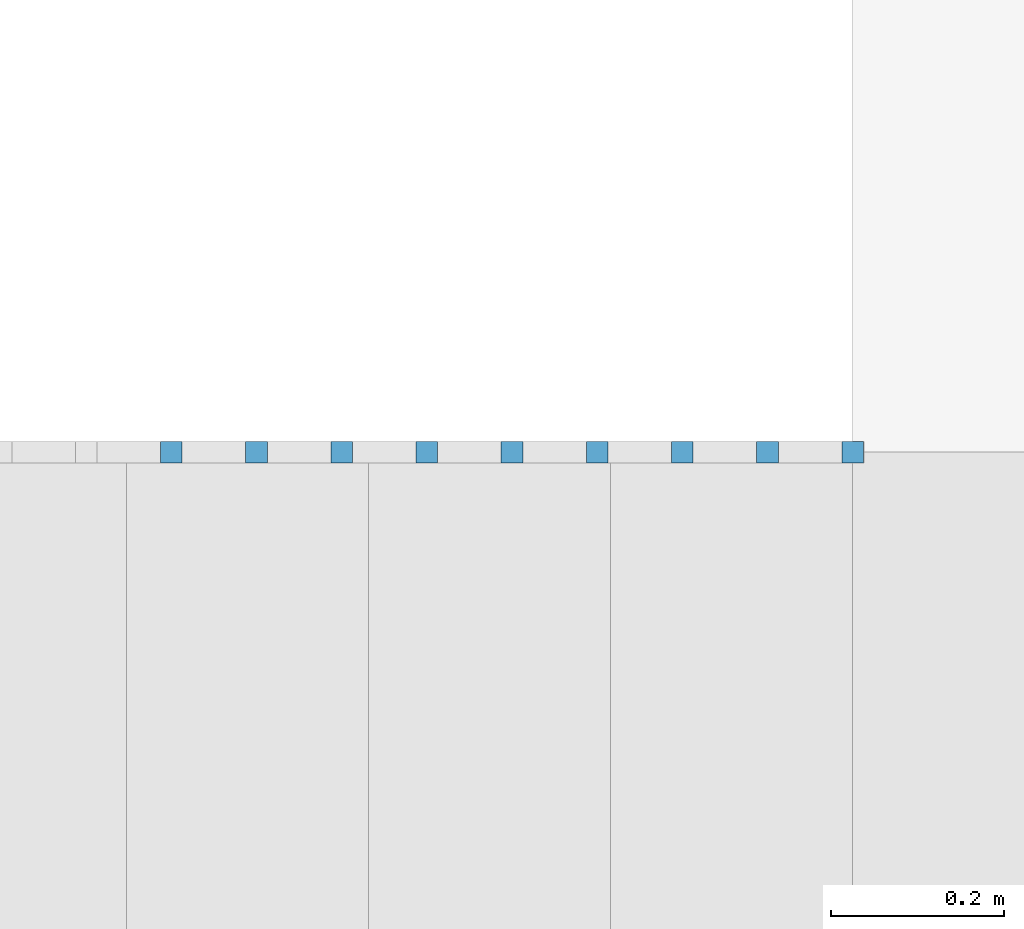
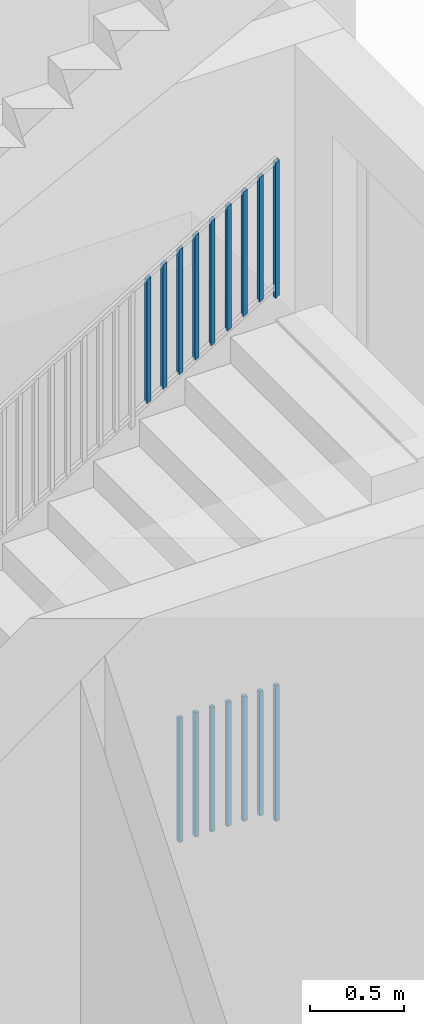
# One storey, part 22 of 23: 16 building element parts, 2 elements without a shape of their own.
"""IFC4 building model written with IfcOpenShell, lengths in metres."""

from ifc_helpers import new_model, entity, si_unit, converted_unit, derived_unit, direction, frame, origin_with_axes, place, context, subcontext, project, spatial, polygons, material, type_object, element, aggregate, save


model = new_model("IFC4")

# Units and contexts
model_context = context("Model", 3, precision=1e-05, world=origin_with_axes(), true_north=direction((0.0, 1.0)))
body_context = subcontext(model_context, "Body", "Model", "MODEL_VIEW")
ifc_project = project(units=[si_unit("LENGTHUNIT", "METRE"), si_unit("AREAUNIT", "SQUARE_METRE"), si_unit("VOLUMEUNIT", "CUBIC_METRE"), converted_unit("PLANEANGLEUNIT", "DEGREE", entity("IfcPlaneAngleMeasure", 0.0174532925199), si_unit("PLANEANGLEUNIT", "RADIAN"), dimensions=[0, 0, 0, 0, 0, 0, 0]), converted_unit("TIMEUNIT", "Year", entity("IfcTimeMeasure", 31556926.0), si_unit("TIMEUNIT", "SECOND"), dimensions=[0, 0, 1, 0, 0, 0, 0]), si_unit("MASSUNIT", "GRAM", prefix="KILO"), si_unit("THERMODYNAMICTEMPERATUREUNIT", "DEGREE_CELSIUS"), si_unit("LUMINOUSINTENSITYUNIT", "LUMEN"), si_unit("ENERGYUNIT", "JOULE", prefix="MEGA"), derived_unit("THERMALCONDUCTANCEUNIT", [(si_unit("POWERUNIT", "WATT"), 1), (si_unit("LENGTHUNIT", "METRE"), -1), (si_unit("THERMODYNAMICTEMPERATUREUNIT", "KELVIN"), -1)]), derived_unit("SPECIFICHEATCAPACITYUNIT", [(si_unit("ENERGYUNIT", "JOULE"), 1), (si_unit("MASSUNIT", "GRAM", prefix="KILO"), -1), (si_unit("THERMODYNAMICTEMPERATUREUNIT", "KELVIN"), -1)]), derived_unit("MASSDENSITYUNIT", [(si_unit("MASSUNIT", "GRAM", prefix="KILO"), 1), (si_unit("VOLUMEUNIT", "CUBIC_METRE"), -1)])], contexts=[model_context])

# Site, building, storey, space
site_placement = place(None, origin_with_axes())
site = spatial("IfcSite", under=ifc_project, at=site_placement, CompositionType="ELEMENT")
building_placement = place(site_placement, origin_with_axes())
building = spatial("IfcBuilding", under=site, at=building_placement, CompositionType="ELEMENT")
storey_placement = place(building_placement, origin_with_axes())
storey = spatial("IfcBuildingStorey", under=building, at=storey_placement, Name="0. Geschoss", CompositionType="ELEMENT", Elevation=0.0)
space_placement = place(storey_placement, frame((-11.4421993804, 1.37118776896, 0.0), z_axis=(0.0, 0.0, 1.0), x_axis=(0.0, -1.0, 0.0)))
space = spatial("IfcSpace", under=storey, at=space_placement, CompositionType="ELEMENT", PredefinedType="INTERNAL")

# Railing, building element parts
railing_type = type_object("IfcRailingType", PredefinedType="NOTDEFINED")
railing_1_placement = place(space_placement, frame((1.5, 8.0, 0.0), z_axis=(0.0, 0.0, 1.0), x_axis=(0.0, 1.0, 0.0)))
railing_1 = element("IfcRailing", 1, at=railing_1_placement, inside=space, type_object=railing_type, PredefinedType="NOTDEFINED")
ifc_material = material()
building_element_part_1_placement = place(railing_1_placement, origin_with_axes())
building_element_part_1 = element("IfcBuildingElementPart", 2, at=building_element_part_1_placement, material=ifc_material, PredefinedType="NOTDEFINED", context=body_context, shape_type="Tessellation", body=[
    polygons([(4.4925, -0.9125, 0.0), (4.4925, -0.8875, 0.0), (4.4925, -0.8875, 0.88), (4.4925, -0.9125, 0.88), (4.4675, -0.9125, 0.0), (4.4675, -0.8875, 0.0), (4.4675, -0.8875, 0.88), (4.4675, -0.9125, 0.88)], [[[1, 2, 3, 4]], [[1, 5, 6, 2]], [[2, 6, 7, 3]], [[4, 3, 7, 8]], [[5, 1, 4, 8]], [[6, 5, 8, 7]]], closed=True),
])
building_element_part_2_placement = place(railing_1_placement, origin_with_axes())
building_element_part_2 = element("IfcBuildingElementPart", 3, at=building_element_part_2_placement, material=ifc_material, PredefinedType="NOTDEFINED", context=body_context, shape_type="Tessellation", body=[
    polygons([(3.90138888889, -0.9125, 0.07), (3.90138888889, -0.8875, 0.07), (3.90138888889, -0.8875, 0.8775), (3.90138888889, -0.9125, 0.8775), (3.87638888889, -0.9125, 0.07), (3.87638888889, -0.8875, 0.07), (3.87638888889, -0.8875, 0.8775), (3.87638888889, -0.9125, 0.8775)], [[[1, 2, 3, 4]], [[1, 5, 6, 2]], [[2, 6, 7, 3]], [[4, 3, 7, 8]], [[5, 1, 4, 8]], [[6, 5, 8, 7]]], closed=True),
])
building_element_part_3_placement = place(railing_1_placement, origin_with_axes())
building_element_part_3 = element("IfcBuildingElementPart", 4, at=building_element_part_3_placement, material=ifc_material, PredefinedType="NOTDEFINED", context=body_context, shape_type="Tessellation", body=[
    polygons([(3.99990740741, -0.9125, 0.07), (3.99990740741, -0.8875, 0.07), (3.99990740741, -0.8875, 0.8775), (3.99990740741, -0.9125, 0.8775), (3.97490740741, -0.9125, 0.07), (3.97490740741, -0.8875, 0.07), (3.97490740741, -0.8875, 0.8775), (3.97490740741, -0.9125, 0.8775)], [[[1, 2, 3, 4]], [[1, 5, 6, 2]], [[2, 6, 7, 3]], [[4, 3, 7, 8]], [[5, 1, 4, 8]], [[6, 5, 8, 7]]], closed=True),
])
building_element_part_4_placement = place(railing_1_placement, origin_with_axes())
building_element_part_4 = element("IfcBuildingElementPart", 5, at=building_element_part_4_placement, material=ifc_material, PredefinedType="NOTDEFINED", context=body_context, shape_type="Tessellation", body=[
    polygons([(4.09842592593, -0.9125, 0.07), (4.09842592593, -0.8875, 0.07), (4.09842592593, -0.8875, 0.8775), (4.09842592593, -0.9125, 0.8775), (4.07342592593, -0.9125, 0.07), (4.07342592593, -0.8875, 0.07), (4.07342592593, -0.8875, 0.8775), (4.07342592593, -0.9125, 0.8775)], [[[1, 2, 3, 4]], [[1, 5, 6, 2]], [[2, 6, 7, 3]], [[4, 3, 7, 8]], [[5, 1, 4, 8]], [[6, 5, 8, 7]]], closed=True),
])
building_element_part_5_placement = place(railing_1_placement, origin_with_axes())
building_element_part_5 = element("IfcBuildingElementPart", 6, at=building_element_part_5_placement, material=ifc_material, PredefinedType="NOTDEFINED", context=body_context, shape_type="Tessellation", body=[
    polygons([(4.19694444444, -0.9125, 0.07), (4.19694444444, -0.8875, 0.07), (4.19694444444, -0.8875, 0.8775), (4.19694444444, -0.9125, 0.8775), (4.17194444444, -0.9125, 0.07), (4.17194444444, -0.8875, 0.07), (4.17194444444, -0.8875, 0.8775), (4.17194444444, -0.9125, 0.8775)], [[[1, 2, 3, 4]], [[1, 5, 6, 2]], [[2, 6, 7, 3]], [[4, 3, 7, 8]], [[5, 1, 4, 8]], [[6, 5, 8, 7]]], closed=True),
])
building_element_part_6_placement = place(railing_1_placement, origin_with_axes())
building_element_part_6 = element("IfcBuildingElementPart", 7, at=building_element_part_6_placement, material=ifc_material, PredefinedType="NOTDEFINED", context=body_context, shape_type="Tessellation", body=[
    polygons([(4.29546296296, -0.9125, 0.07), (4.29546296296, -0.8875, 0.07), (4.29546296296, -0.8875, 0.8775), (4.29546296296, -0.9125, 0.8775), (4.27046296296, -0.9125, 0.07), (4.27046296296, -0.8875, 0.07), (4.27046296296, -0.8875, 0.8775), (4.27046296296, -0.9125, 0.8775)], [[[1, 2, 3, 4]], [[1, 5, 6, 2]], [[2, 6, 7, 3]], [[4, 3, 7, 8]], [[5, 1, 4, 8]], [[6, 5, 8, 7]]], closed=True),
])
building_element_part_7_placement = place(railing_1_placement, origin_with_axes())
building_element_part_7 = element("IfcBuildingElementPart", 8, at=building_element_part_7_placement, material=ifc_material, PredefinedType="NOTDEFINED", context=body_context, shape_type="Tessellation", body=[
    polygons([(4.39398148148, -0.9125, 0.07), (4.39398148148, -0.8875, 0.07), (4.39398148148, -0.8875, 0.8775), (4.39398148148, -0.9125, 0.8775), (4.36898148148, -0.9125, 0.07), (4.36898148148, -0.8875, 0.07), (4.36898148148, -0.8875, 0.8775), (4.36898148148, -0.9125, 0.8775)], [[[1, 2, 3, 4]], [[1, 5, 6, 2]], [[2, 6, 7, 3]], [[4, 3, 7, 8]], [[5, 1, 4, 8]], [[6, 5, 8, 7]]], closed=True),
])
aggregate(railing_1, [building_element_part_1, building_element_part_2, building_element_part_3, building_element_part_4, building_element_part_5, building_element_part_6, building_element_part_7])

railing_2_placement = place(space_placement, frame((2.4, 7.16, 0.17), z_axis=(0.0, 0.0, 1.0), x_axis=(0.0, 1.0, 0.0)))
railing_2 = element("IfcRailing", 9, at=railing_2_placement, inside=space, type_object=railing_type, PredefinedType="NOTDEFINED")
building_element_part_8_placement = place(railing_2_placement, origin_with_axes())
building_element_part_8 = element("IfcBuildingElementPart", 10, at=building_element_part_8_placement, material=ifc_material, PredefinedType="NOTDEFINED", context=body_context, shape_type="Tessellation", body=[
    polygons([(5.3325, -0.0125, 3.23758928571), (5.3325, 0.0125, 3.23758928571), (5.3325, 0.0125, 4.11758928571), (5.3325, -0.0125, 4.11758928571), (5.3075, -0.0125, 3.22241071429), (5.3075, 0.0125, 3.22241071429), (5.3075, 0.0125, 4.10241071429), (5.3075, -0.0125, 4.10241071429)], [[[1, 2, 3, 4]], [[1, 5, 6, 2]], [[2, 6, 7, 3]], [[4, 3, 7, 8]], [[5, 1, 4, 8]], [[6, 5, 8, 7]]], closed=True),
])
building_element_part_9_placement = place(railing_2_placement, origin_with_axes())
building_element_part_9 = element("IfcBuildingElementPart", 11, at=building_element_part_9_placement, material=ifc_material, PredefinedType="NOTDEFINED", context=body_context, shape_type="Tessellation", body=[
    polygons([(4.54435185185, -0.0125, 2.8290707672), (4.54435185185, 0.0125, 2.8290707672), (4.54435185185, 0.0125, 3.6365707672), (4.54435185185, -0.0125, 3.6365707672), (4.51935185185, -0.0125, 2.81389219577), (4.51935185185, 0.0125, 2.81389219577), (4.51935185185, 0.0125, 3.62139219577), (4.51935185185, -0.0125, 3.62139219577)], [[[1, 2, 3, 4]], [[1, 5, 6, 2]], [[2, 6, 7, 3]], [[4, 3, 7, 8]], [[5, 1, 4, 8]], [[6, 5, 8, 7]]], closed=True),
])
building_element_part_10_placement = place(railing_2_placement, origin_with_axes())
building_element_part_10 = element("IfcBuildingElementPart", 12, at=building_element_part_10_placement, material=ifc_material, PredefinedType="NOTDEFINED", context=body_context, shape_type="Tessellation", body=[
    polygons([(4.64287037037, -0.0125, 2.88888558201), (4.64287037037, 0.0125, 2.88888558201), (4.64287037037, 0.0125, 3.69638558201), (4.64287037037, -0.0125, 3.69638558201), (4.61787037037, -0.0125, 2.87370701058), (4.61787037037, 0.0125, 2.87370701058), (4.61787037037, 0.0125, 3.68120701058), (4.61787037037, -0.0125, 3.68120701058)], [[[1, 2, 3, 4]], [[1, 5, 6, 2]], [[2, 6, 7, 3]], [[4, 3, 7, 8]], [[5, 1, 4, 8]], [[6, 5, 8, 7]]], closed=True),
])
building_element_part_11_placement = place(railing_2_placement, origin_with_axes())
building_element_part_11 = element("IfcBuildingElementPart", 13, at=building_element_part_11_placement, material=ifc_material, PredefinedType="NOTDEFINED", context=body_context, shape_type="Tessellation", body=[
    polygons([(4.74138888889, -0.0125, 2.94870039683), (4.74138888889, 0.0125, 2.94870039683), (4.74138888889, 0.0125, 3.75620039683), (4.74138888889, -0.0125, 3.75620039683), (4.71638888889, -0.0125, 2.9335218254), (4.71638888889, 0.0125, 2.9335218254), (4.71638888889, 0.0125, 3.7410218254), (4.71638888889, -0.0125, 3.7410218254)], [[[1, 2, 3, 4]], [[1, 5, 6, 2]], [[2, 6, 7, 3]], [[4, 3, 7, 8]], [[5, 1, 4, 8]], [[6, 5, 8, 7]]], closed=True),
])
building_element_part_12_placement = place(railing_2_placement, origin_with_axes())
building_element_part_12 = element("IfcBuildingElementPart", 14, at=building_element_part_12_placement, material=ifc_material, PredefinedType="NOTDEFINED", context=body_context, shape_type="Tessellation", body=[
    polygons([(4.83990740741, -0.0125, 3.00851521164), (4.83990740741, 0.0125, 3.00851521164), (4.83990740741, 0.0125, 3.81601521164), (4.83990740741, -0.0125, 3.81601521164), (4.81490740741, -0.0125, 2.99333664021), (4.81490740741, 0.0125, 2.99333664021), (4.81490740741, 0.0125, 3.80083664021), (4.81490740741, -0.0125, 3.80083664021)], [[[1, 2, 3, 4]], [[1, 5, 6, 2]], [[2, 6, 7, 3]], [[4, 3, 7, 8]], [[5, 1, 4, 8]], [[6, 5, 8, 7]]], closed=True),
])
building_element_part_13_placement = place(railing_2_placement, origin_with_axes())
building_element_part_13 = element("IfcBuildingElementPart", 15, at=building_element_part_13_placement, material=ifc_material, PredefinedType="NOTDEFINED", context=body_context, shape_type="Tessellation", body=[
    polygons([(4.93842592593, -0.0125, 3.06833002646), (4.93842592593, 0.0125, 3.06833002646), (4.93842592593, 0.0125, 3.87583002646), (4.93842592593, -0.0125, 3.87583002646), (4.91342592593, -0.0125, 3.05315145503), (4.91342592593, 0.0125, 3.05315145503), (4.91342592593, 0.0125, 3.86065145503), (4.91342592593, -0.0125, 3.86065145503)], [[[1, 2, 3, 4]], [[1, 5, 6, 2]], [[2, 6, 7, 3]], [[4, 3, 7, 8]], [[5, 1, 4, 8]], [[6, 5, 8, 7]]], closed=True),
])
building_element_part_14_placement = place(railing_2_placement, origin_with_axes())
building_element_part_14 = element("IfcBuildingElementPart", 16, at=building_element_part_14_placement, material=ifc_material, PredefinedType="NOTDEFINED", context=body_context, shape_type="Tessellation", body=[
    polygons([(5.03694444444, -0.0125, 3.12814484127), (5.03694444444, 0.0125, 3.12814484127), (5.03694444444, 0.0125, 3.93564484127), (5.03694444444, -0.0125, 3.93564484127), (5.01194444444, -0.0125, 3.11296626984), (5.01194444444, 0.0125, 3.11296626984), (5.01194444444, 0.0125, 3.92046626984), (5.01194444444, -0.0125, 3.92046626984)], [[[1, 2, 3, 4]], [[1, 5, 6, 2]], [[2, 6, 7, 3]], [[4, 3, 7, 8]], [[5, 1, 4, 8]], [[6, 5, 8, 7]]], closed=True),
])
building_element_part_15_placement = place(railing_2_placement, origin_with_axes())
building_element_part_15 = element("IfcBuildingElementPart", 17, at=building_element_part_15_placement, material=ifc_material, PredefinedType="NOTDEFINED", context=body_context, shape_type="Tessellation", body=[
    polygons([(5.13546296296, -0.0125, 3.18795965608), (5.13546296296, 0.0125, 3.18795965608), (5.13546296296, 0.0125, 3.99545965608), (5.13546296296, -0.0125, 3.99545965608), (5.11046296296, -0.0125, 3.17278108466), (5.11046296296, 0.0125, 3.17278108466), (5.11046296296, 0.0125, 3.98028108466), (5.11046296296, -0.0125, 3.98028108466)], [[[1, 2, 3, 4]], [[1, 5, 6, 2]], [[2, 6, 7, 3]], [[4, 3, 7, 8]], [[5, 1, 4, 8]], [[6, 5, 8, 7]]], closed=True),
])
building_element_part_16_placement = place(railing_2_placement, origin_with_axes())
building_element_part_16 = element("IfcBuildingElementPart", 18, at=building_element_part_16_placement, material=ifc_material, PredefinedType="NOTDEFINED", context=body_context, shape_type="Tessellation", body=[
    polygons([(5.23398148148, -0.0125, 3.2477744709), (5.23398148148, 0.0125, 3.2477744709), (5.23398148148, 0.0125, 4.0552744709), (5.23398148148, -0.0125, 4.0552744709), (5.20898148148, -0.0125, 3.23259589947), (5.20898148148, 0.0125, 3.23259589947), (5.20898148148, 0.0125, 4.04009589947), (5.20898148148, -0.0125, 4.04009589947)], [[[1, 2, 3, 4]], [[1, 5, 6, 2]], [[2, 6, 7, 3]], [[4, 3, 7, 8]], [[5, 1, 4, 8]], [[6, 5, 8, 7]]], closed=True),
])
aggregate(railing_2, [building_element_part_8, building_element_part_9, building_element_part_10, building_element_part_11, building_element_part_12, building_element_part_13, building_element_part_14, building_element_part_15, building_element_part_16])

save(model, "model.ifc")
